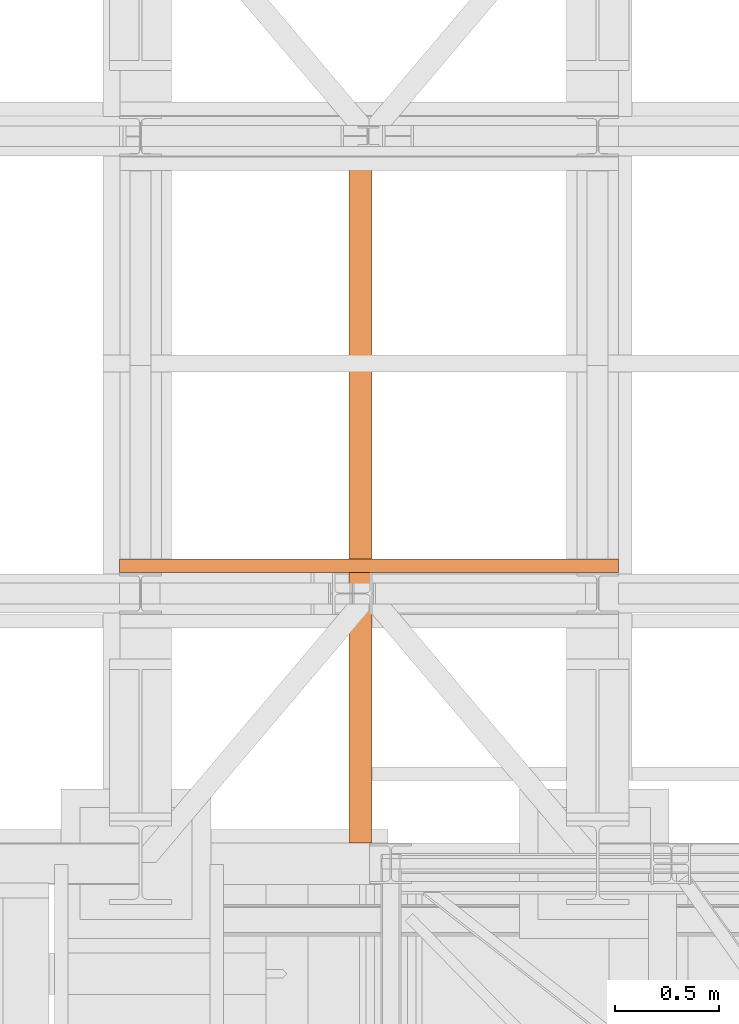
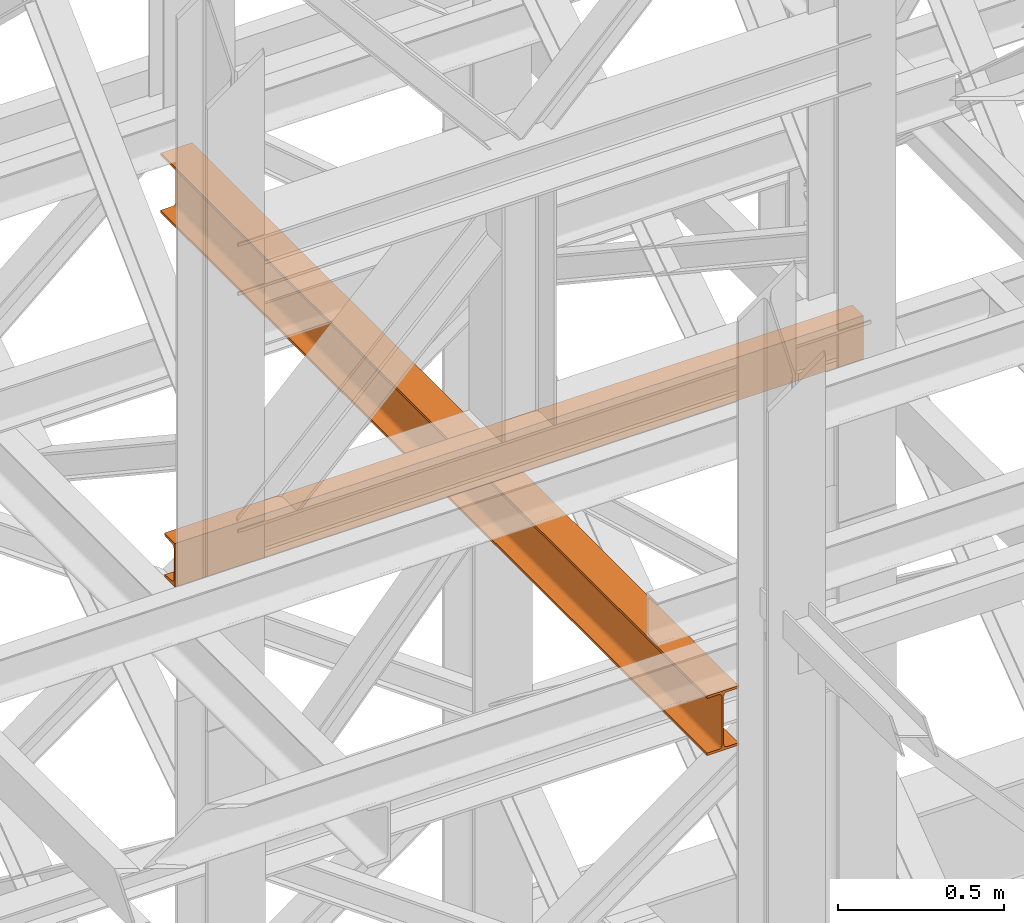
# One storey, part 111 of 208: 2 proxies.
"""IFC2X3 building model written with IfcOpenShell, lengths in millimetres."""

from ifc_helpers import new_model, entity, si_unit, converted_unit, frame, origin, origin_with_axes, place, context, subcontext, project, spatial, faceted_brep, element, save


model = new_model("IFC2X3")

# Units and contexts
model_context = context("Model", 3, precision=1e-05, world=origin())
plan_context = context("Plan", 3, precision=1e-05, world=origin())
body_context = subcontext(model_context, "Body", "Model", "MODEL_VIEW")
ifc_project = project(units=[si_unit("LENGTHUNIT", "METRE", prefix="MILLI"), converted_unit("PLANEANGLEUNIT", "DEGREE", entity("IfcPlaneAngleMeasure", 0.0174532925199433), si_unit("PLANEANGLEUNIT", "RADIAN"), dimensions=[0, 0, 0, 0, 0, 0, 0]), si_unit("AREAUNIT", "SQUARE_METRE"), si_unit("VOLUMEUNIT", "CUBIC_METRE")], contexts=[model_context, plan_context])

# Building, storey
building_placement = place(None, origin())
building = spatial("IfcBuilding", under=ifc_project, at=building_placement, CompositionType="COMPLEX")
storey_placement = place(building_placement, origin_with_axes())
storey = spatial("IfcBuildingStorey", under=building, at=storey_placement, Name="Geschoss", CompositionType="ELEMENT")

# Proxies
proxy_1_placement = place(storey_placement, frame((-106.7741512795017, -15862.57605638884, 9699.99), z_axis=(0.0, 0.0, 1.0), x_axis=(1.0, 0.0, 0.0)))
element("IfcBuildingElementProxy", 1, at=proxy_1_placement, inside=storey, context=body_context, shape_type="Brep", body=[
    faceted_brep([(0.009999999999990905, 65.01181901812197, 0.01000000000021828), (2399.826087056121, 65.01000000000022, 0.01000000000021828), (2399.826087056121, 65.01000000000022, 3.132428070246533), (0.009999999999990905, 65.01181901812197, 3.132428070246533), (0.009999999999990905, 65.01181901812197, 3.132428070246533), (2399.826087056121, 65.01000000000022, 3.132428070246533), (2399.826087056121, 64.76726342282564, 4.748288908171162), (0.009999999999990905, 64.7690824409492, 4.748288908171162), (0.009999999999990905, 64.7690824409492, 4.748288908171162), (2399.826087056121, 64.76726342282564, 4.748288908171162), (2399.826087056121, 64.06053228585552, 6.221534443444398), (0.009999999999990905, 64.06235130397909, 6.221534443444398), (0.009999999999990905, 64.06235130397909, 6.221534443444398), (2399.826087056121, 64.06053228585552, 6.221534443444398), (2399.826087056121, 62.95215163846842, 7.422126703873801), (0.009999999999990905, 62.95397065659199, 7.422126703873801), (0.009999999999990905, 62.95397065659199, 7.422126703873801), (2399.826087056121, 62.95215163846842, 7.422126703873801), (2399.826087056121, 61.53995641148504, 8.244091391710754), (0.009999999999990905, 61.54177542960679, 8.244091391710754), (0.009999999999990905, 61.54177542960679, 8.244091391710754), (2399.826087056121, 61.53995641148504, 8.244091391710754), (2399.826087056121, 59.9485987225562, 8.614912102195376), (0.009999999999990905, 59.95041774067795, 8.614912102195376), (0.009999999999990905, 59.95041774067795, 8.614912102195376), (2399.826087056121, 59.9485987225562, 8.614912102195376), (2399.826087056121, 17.17267516602988, 12.0369859867169), (0.009999999999990905, 17.17449418415163, 12.0369859867169), (0.009999999999990905, 17.17449418415163, 12.0369859867169), (2399.826087056121, 17.17267516602988, 12.0369859867169), (2399.826087056121, 14.13462866898408, 12.74491643400506), (0.009999999999990905, 14.13644768710583, 12.74491643400506), (0.009999999999990905, 14.13644768710583, 12.74491643400506), (2399.826087056121, 14.13462866898408, 12.74491643400506), (2399.826087056121, 11.43861959928654, 14.31412174714933), (0.009999999999990905, 11.44043861740829, 14.31412174714933), (0.009999999999990905, 11.44043861740829, 14.31412174714933), (2399.826087056121, 11.43861959928654, 14.31412174714933), (2399.826087056121, 9.322620181546881, 16.60616151705835), (0.009999999999990905, 9.324439199668632, 16.60616151705835), (0.009999999999990905, 9.324439199668632, 16.60616151705835), (2399.826087056121, 9.322620181546881, 16.60616151705835), (2399.826087056121, 7.973406192784751, 19.41872117530875), (0.009999999999990905, 7.97522521090832, 19.41872117530875), (0.009999999999990905, 7.97522521090832, 19.41872117530875), (2399.826087056121, 7.973406192784751, 19.41872117530875), (2399.826087056121, 7.510000000000218, 22.50354641134618), (0.009999999999990905, 7.511819018121969, 22.50354641134618), (0.009999999999990905, 7.511819018121969, 22.50354641134618), (2399.826087056121, 7.510000000000218, 22.50354641134618), (2399.826087056121, 7.510000000000218, 137.5164535886524), (0.009999999999990905, 7.511819018121969, 137.5164535886524), (0.009999999999990905, 7.511819018121969, 137.5164535886524), (2399.826087056121, 7.510000000000218, 137.5164535886524), (2399.826087056121, 7.973406192784751, 140.6012788246917), (0.009999999999990905, 7.97522521090832, 140.6012788246917), (0.009999999999990905, 7.97522521090832, 140.6012788246917), (2399.826087056121, 7.973406192784751, 140.6012788246917), (2399.826087056121, 9.322620181546881, 143.4138384829403), (0.009999999999990905, 9.324439199668632, 143.4138384829403), (0.009999999999990905, 9.324439199668632, 143.4138384829403), (2399.826087056121, 9.322620181546881, 143.4138384829403), (2399.826087056121, 11.43861959928654, 145.7058782528493), (0.009999999999990905, 11.44043861740829, 145.7058782528493), (0.009999999999990905, 11.44043861740829, 145.7058782528493), (2399.826087056121, 11.43861959928654, 145.7058782528493), (2399.826087056121, 14.13462866898408, 147.2750835659936), (0.009999999999990905, 14.13644768710583, 147.2750835659936), (0.009999999999990905, 14.13644768710583, 147.2750835659936), (2399.826087056121, 14.13462866898408, 147.2750835659936), (2399.826087056121, 17.17267516602988, 147.9830140132817), (0.009999999999990905, 17.17449418415163, 147.9830140132817), (0.009999999999990905, 17.17449418415163, 147.9830140132817), (2399.826087056121, 17.17267516602988, 147.9830140132817), (2399.826087056121, 59.9485987225562, 151.4050878978032), (0.009999999999990905, 59.95041774067795, 151.4050878978032), (0.009999999999990905, 59.95041774067795, 151.4050878978032), (2399.826087056121, 59.9485987225562, 151.4050878978032), (2399.826087056121, 61.53995641148504, 151.7759086082879), (0.009999999999990905, 61.54177542960679, 151.7759086082879), (0.009999999999990905, 61.54177542960679, 151.7759086082879), (2399.826087056121, 61.53995641148504, 151.7759086082879), (2399.826087056121, 62.95215163846842, 152.5978732961248), (0.009999999999990905, 62.95397065659199, 152.5978732961248), (0.009999999999990905, 62.95397065659199, 152.5978732961248), (2399.826087056121, 62.95215163846842, 152.5978732961248), (2399.826087056121, 64.06053228585552, 153.7984655565542), (0.009999999999990905, 64.06235130397909, 153.7984655565542), (0.009999999999990905, 64.06235130397909, 153.7984655565542), (2399.826087056121, 64.06053228585552, 153.7984655565542), (2399.826087056121, 64.76726342282564, 155.2717110918275), (0.009999999999990905, 64.7690824409492, 155.2717110918275), (0.009999999999990905, 64.7690824409492, 155.2717110918275), (2399.826087056121, 64.76726342282564, 155.2717110918275), (2399.826087056121, 65.01000000000022, 156.8875719297521), (0.009999999999990905, 65.01181901812197, 156.8875719297521), (0.009999999999990905, 65.01181901812197, 156.8875719297521), (2399.826087056121, 65.01000000000022, 156.8875719297521), (2399.826087056121, 65.01000000000022, 160.0100000000002), (0.009999999999990905, 65.01181901812197, 160.0100000000002), (0.009999999999990905, 65.01181901812197, 160.0100000000002), (2399.826087056121, 65.01000000000022, 160.0100000000002), (2399.826087056121, 0.01000000000021828, 160.0100000000002), (0.009999999999990905, 0.01181901812196884, 160.0100000000002), (0.009999999999990905, 0.01181901812196884, 160.0100000000002), (2399.826087056121, 0.01000000000021828, 160.0100000000002), (2399.826087056121, 0.01000000000021828, 0.01000000000021828), (0.009999999999990905, 0.01181901812196884, 0.01000000000021828), (0.009999999999990905, 0.01181901812196884, 0.01000000000021828), (2399.826087056121, 0.01000000000021828, 0.01000000000021828), (2399.826087056121, 65.01000000000022, 0.01000000000021828), (0.009999999999990905, 65.01181901812197, 0.01000000000021828), (0.009999999999990905, 65.01181901812197, 0.01000000000021828), (0.009999999999990905, 65.01181901812197, 3.132428070246533), (0.009999999999990905, 64.7690824409492, 4.748288908171162), (0.009999999999990905, 64.06235130397909, 6.221534443444398), (0.009999999999990905, 62.95397065659199, 7.422126703873801), (0.009999999999990905, 61.54177542960679, 8.244091391710754), (0.009999999999990905, 59.95041774067795, 8.614912102195376), (0.009999999999990905, 17.17449418415163, 12.0369859867169), (0.009999999999990905, 14.13644768710583, 12.74491643400506), (0.009999999999990905, 11.44043861740829, 14.31412174714933), (0.009999999999990905, 9.324439199668632, 16.60616151705835), (0.009999999999990905, 7.97522521090832, 19.41872117530875), (0.009999999999990905, 7.511819018121969, 22.50354641134618), (0.009999999999990905, 7.511819018121969, 137.5164535886524), (0.009999999999990905, 7.97522521090832, 140.6012788246917), (0.009999999999990905, 9.324439199668632, 143.4138384829403), (0.009999999999990905, 11.44043861740829, 145.7058782528493), (0.009999999999990905, 14.13644768710583, 147.2750835659936), (0.009999999999990905, 17.17449418415163, 147.9830140132817), (0.009999999999990905, 59.95041774067795, 151.4050878978032), (0.009999999999990905, 61.54177542960679, 151.7759086082879), (0.009999999999990905, 62.95397065659199, 152.5978732961248), (0.009999999999990905, 64.06235130397909, 153.7984655565542), (0.009999999999990905, 64.7690824409492, 155.2717110918275), (0.009999999999990905, 65.01181901812197, 156.8875719297521), (0.009999999999990905, 65.01181901812197, 160.0100000000002), (0.009999999999990905, 0.01181901812196884, 160.0100000000002), (0.009999999999990905, 0.01181901812196884, 0.01000000000021828), (2399.826087056121, 65.01000000000022, 0.01000000000021828), (2399.826087056121, 0.01000000000021828, 0.01000000000021828), (2399.826087056121, 0.01000000000021828, 160.0100000000002), (2399.826087056121, 65.01000000000022, 160.0100000000002), (2399.826087056121, 65.01000000000022, 156.8875719297521), (2399.826087056121, 64.76726342282564, 155.2717110918275), (2399.826087056121, 64.06053228585552, 153.7984655565542), (2399.826087056121, 62.95215163846842, 152.5978732961248), (2399.826087056121, 61.53995641148504, 151.7759086082879), (2399.826087056121, 59.9485987225562, 151.4050878978032), (2399.826087056121, 17.17267516602988, 147.9830140132817), (2399.826087056121, 14.13462866898408, 147.2750835659936), (2399.826087056121, 11.43861959928654, 145.7058782528493), (2399.826087056121, 9.322620181546881, 143.4138384829403), (2399.826087056121, 7.973406192784751, 140.6012788246917), (2399.826087056121, 7.510000000000218, 137.5164535886524), (2399.826087056121, 7.510000000000218, 22.50354641134618), (2399.826087056121, 7.973406192784751, 19.41872117530875), (2399.826087056121, 9.322620181546881, 16.60616151705835), (2399.826087056121, 11.43861959928654, 14.31412174714933), (2399.826087056121, 14.13462866898408, 12.74491643400506), (2399.826087056121, 17.17267516602988, 12.0369859867169), (2399.826087056121, 59.9485987225562, 8.614912102195376), (2399.826087056121, 61.53995641148504, 8.244091391710754), (2399.826087056121, 62.95215163846842, 7.422126703873801), (2399.826087056121, 64.06053228585552, 6.221534443444398), (2399.826087056121, 64.76726342282564, 4.748288908171162), (2399.826087056121, 65.01000000000022, 3.132428070246533)], [[[0, 1, 2, 3]], [[4, 5, 6, 7]], [[8, 9, 10, 11]], [[12, 13, 14, 15]], [[16, 17, 18, 19]], [[20, 21, 22, 23]], [[24, 25, 26, 27]], [[28, 29, 30, 31]], [[32, 33, 34, 35]], [[36, 37, 38, 39]], [[40, 41, 42, 43]], [[44, 45, 46, 47]], [[48, 49, 50, 51]], [[52, 53, 54, 55]], [[56, 57, 58, 59]], [[60, 61, 62, 63]], [[64, 65, 66, 67]], [[68, 69, 70, 71]], [[72, 73, 74, 75]], [[76, 77, 78, 79]], [[80, 81, 82, 83]], [[84, 85, 86, 87]], [[88, 89, 90, 91]], [[92, 93, 94, 95]], [[96, 97, 98, 99]], [[100, 101, 102, 103]], [[104, 105, 106, 107]], [[108, 109, 110, 111]], [[112, 113, 114, 115, 116, 117, 118, 119, 120, 121, 122, 123, 124, 125, 126, 127, 128, 129, 130, 131, 132, 133, 134, 135, 136, 137, 138, 139]], [[140, 141, 142, 143, 144, 145, 146, 147, 148, 149, 150, 151, 152, 153, 154, 155, 156, 157, 158, 159, 160, 161, 162, 163, 164, 165, 166, 167]]], orient=[[False], [False], [False], [False], [False], [False], [False], [False], [False], [False], [False], [False], [False], [False], [False], [False], [False], [False], [False], [False], [False], [False], [False], [False], [False], [False], [False], [False], [False], [False]]),
])
proxy_2_placement = place(storey_placement, frame((997.4990363434483, -17162.58508944891, 9479.99), z_axis=(0.0, 0.0, 1.0), x_axis=(1.0, 0.0, 0.0)))
element("IfcBuildingElementProxy", 2, at=proxy_2_placement, inside=storey, Name="3D Element", context=body_context, shape_type="Brep", body=[
    faceted_brep([(0.009999999999990905, 3299.938194702263, 9.209999809265355), (0.009999999999990905, 3299.938194702263, 0.01000000000021828), (110.01, 3299.938194702263, 0.01000000000021828), (110.01, 3299.938194702263, 9.209999809265355), (70.57913068098946, 3299.938194702263, 9.209999809265355), (66.25180869396877, 3299.938194702263, 9.797362501594762), (62.90658890732789, 3299.938194702263, 11.50181071442057), (60.25181095283892, 3299.938194702263, 14.15658866890954), (58.54736274001311, 3299.938194702263, 17.50180845555042), (57.96000004768371, 3299.938194702263, 21.20999980926536), (57.96000004768371, 3299.938194702263, 198.8100001907351), (58.3689252976817, 3299.938194702263, 201.915818315525), (59.56772743354645, 3299.938194702263, 204.8099826905327), (61.47471867344552, 3299.938194702263, 207.2952815649733), (63.9600175478879, 3299.938194702263, 209.2022728048742), (66.85418192289376, 3299.938194702263, 210.4010749407371), (69.9600000476837, 3299.938194702263, 210.8100001907351), (110.01, 3299.938194702263, 210.8100001907351), (110.01, 3299.938194702263, 220.0100000000002), (0.009999999999990905, 3299.938194702263, 220.0100000000002), (0.009999999999990905, 3299.938194702263, 210.8100001907351), (40.05999995231628, 3299.938194702263, 210.8100001907351), (43.16581807710622, 3299.938194702263, 210.4010749407371), (46.0599824521139, 3299.938194702263, 209.2022728048742), (48.54528132655446, 3299.938194702263, 207.2952815649733), (50.52982171082635, 3299.938194702263, 204.6227624944386), (51.6510747023201, 3299.938194702263, 201.915818315525), (52.05999995231628, 3299.938194702263, 198.8100001907351), (52.05999995231628, 3299.938194702263, 21.20999980926536), (51.6510747023201, 3299.938194702263, 18.10418168447541), (50.45227256645535, 3299.938194702263, 15.21001730946955), (48.54528132655446, 3299.938194702263, 12.72471843502717), (46.0599824521139, 3299.938194702263, 10.81772719512628), (43.16581807710622, 3299.938194702263, 9.618925059263347), (40.05999995231628, 3299.938194702263, 9.209999809265355), (0.009999999999990905, 3299.938194702263, 0.01000000000021828), (0.009999999999990905, 3299.938194702263, 9.209999809265355), (0.009999999999990905, 0.00999999999839929, 9.209999809265355), (0.009999999999990905, 0.00999999999839929, 0.01000000000021828), (110.01, 3299.938194702263, 0.01000000000021828), (0.009999999999990905, 3299.938194702263, 0.01000000000021828), (0.009999999999990905, 0.00999999999839929, 0.01000000000021828), (110.01, 0.00999999999839929, 0.01000000000021828), (110.01, 3299.938194702263, 9.209999809265355), (110.01, 3299.938194702263, 0.01000000000021828), (110.01, 0.00999999999839929, 0.01000000000021828), (110.01, 0.00999999999839929, 9.209999809265355), (70.57913068098946, 3299.938194702263, 9.209999809265355), (110.01, 3299.938194702263, 9.209999809265355), (110.01, 0.00999999999839929, 9.209999809265355), (70.57913068098946, 0.00999999999839929, 9.209999809265355), (66.25180869396877, 3299.938194702263, 9.797362501594762), (70.57913068098946, 3299.938194702263, 9.209999809265355), (70.57913068098946, 0.00999999999839929, 9.209999809265355), (66.25180869396877, 0.00999999999839929, 9.797362501594762), (62.90658890732789, 3299.938194702263, 11.50181071442057), (66.25180869396877, 3299.938194702263, 9.797362501594762), (66.25180869396877, 0.00999999999839929, 9.797362501594762), (62.90658890732789, 0.00999999999839929, 11.50181071442057), (60.25181095283892, 3299.938194702263, 14.15658866890954), (62.90658890732789, 3299.938194702263, 11.50181071442057), (62.90658890732789, 0.00999999999839929, 11.50181071442057), (60.25181095283892, 0.00999999999839929, 14.15658866890954), (58.54736274001311, 3299.938194702263, 17.50180845555042), (60.25181095283892, 3299.938194702263, 14.15658866890954), (60.25181095283892, 0.00999999999839929, 14.15658866890954), (58.54736274001311, 0.00999999999839929, 17.50180845555042), (57.96000004768371, 3299.938194702263, 21.20999980926536), (58.54736274001311, 3299.938194702263, 17.50180845555042), (58.54736274001311, 0.00999999999839929, 17.50180845555042), (57.96000004768371, 0.00999999999839929, 21.20999980926536), (57.96000004768371, 3299.938194702263, 198.8100001907351), (57.96000004768371, 3299.938194702263, 21.20999980926536), (57.96000004768371, 0.00999999999839929, 21.20999980926536), (57.96000004768371, 0.00999999999839929, 198.8100001907351), (58.3689252976817, 3299.938194702263, 201.915818315525), (57.96000004768371, 3299.938194702263, 198.8100001907351), (57.96000004768371, 0.00999999999839929, 198.8100001907351), (58.3689252976817, 0.00999999999839929, 201.915818315525), (59.56772743354645, 3299.938194702263, 204.8099826905327), (58.3689252976817, 3299.938194702263, 201.915818315525), (58.3689252976817, 0.00999999999839929, 201.915818315525), (59.56772743354645, 0.00999999999839929, 204.8099826905327), (61.47471867344552, 3299.938194702263, 207.2952815649733), (59.56772743354645, 3299.938194702263, 204.8099826905327), (59.56772743354645, 0.00999999999839929, 204.8099826905327), (61.47471867344552, 0.00999999999839929, 207.2952815649733), (63.9600175478879, 3299.938194702263, 209.2022728048742), (61.47471867344552, 3299.938194702263, 207.2952815649733), (61.47471867344552, 0.00999999999839929, 207.2952815649733), (63.9600175478879, 0.00999999999839929, 209.2022728048742), (66.85418192289376, 3299.938194702263, 210.4010749407371), (63.9600175478879, 3299.938194702263, 209.2022728048742), (63.9600175478879, 0.00999999999839929, 209.2022728048742), (66.85418192289376, 0.00999999999839929, 210.4010749407371), (69.9600000476837, 3299.938194702263, 210.8100001907351), (66.85418192289376, 3299.938194702263, 210.4010749407371), (66.85418192289376, 0.00999999999839929, 210.4010749407371), (69.9600000476837, 0.00999999999839929, 210.8100001907351), (110.01, 3299.938194702263, 210.8100001907351), (69.9600000476837, 3299.938194702263, 210.8100001907351), (69.9600000476837, 0.00999999999839929, 210.8100001907351), (110.01, 0.00999999999839929, 210.8100001907351), (110.01, 3299.938194702263, 220.0100000000002), (110.01, 3299.938194702263, 210.8100001907351), (110.01, 0.00999999999839929, 210.8100001907351), (110.01, 0.00999999999839929, 220.0100000000002), (0.009999999999990905, 3299.938194702263, 220.0100000000002), (110.01, 3299.938194702263, 220.0100000000002), (110.01, 0.00999999999839929, 220.0100000000002), (0.009999999999990905, 0.00999999999839929, 220.0100000000002), (0.009999999999990905, 3299.938194702263, 210.8100001907351), (0.009999999999990905, 3299.938194702263, 220.0100000000002), (0.009999999999990905, 0.00999999999839929, 220.0100000000002), (0.009999999999990905, 0.00999999999839929, 210.8100001907351), (40.05999995231628, 3299.938194702263, 210.8100001907351), (0.009999999999990905, 3299.938194702263, 210.8100001907351), (0.009999999999990905, 0.00999999999839929, 210.8100001907351), (40.05999995231628, 0.00999999999839929, 210.8100001907351), (43.16581807710622, 3299.938194702263, 210.4010749407371), (40.05999995231628, 3299.938194702263, 210.8100001907351), (40.05999995231628, 0.00999999999839929, 210.8100001907351), (43.16581807710622, 0.00999999999839929, 210.4010749407371), (46.0599824521139, 3299.938194702263, 209.2022728048742), (43.16581807710622, 3299.938194702263, 210.4010749407371), (43.16581807710622, 0.00999999999839929, 210.4010749407371), (46.0599824521139, 0.00999999999839929, 209.2022728048742), (48.54528132655446, 3299.938194702263, 207.2952815649733), (46.0599824521139, 3299.938194702263, 209.2022728048742), (46.0599824521139, 0.00999999999839929, 209.2022728048742), (48.54528132655446, 0.00999999999839929, 207.2952815649733), (50.52982171082635, 3299.938194702263, 204.6227624944386), (48.54528132655446, 3299.938194702263, 207.2952815649733), (48.54528132655446, 0.00999999999839929, 207.2952815649733), (50.52982171082635, 0.00999999999839929, 204.6227624944386), (51.6510747023201, 3299.938194702263, 201.915818315525), (50.52982171082635, 3299.938194702263, 204.6227624944386), (50.52982171082635, 0.00999999999839929, 204.6227624944386), (51.6510747023201, 0.00999999999839929, 201.915818315525), (52.05999995231628, 3299.938194702263, 198.8100001907351), (51.6510747023201, 3299.938194702263, 201.915818315525), (51.6510747023201, 0.00999999999839929, 201.915818315525), (52.05999995231628, 0.00999999999839929, 198.8100001907351), (52.05999995231628, 3299.938194702263, 21.20999980926536), (52.05999995231628, 3299.938194702263, 198.8100001907351), (52.05999995231628, 0.00999999999839929, 198.8100001907351), (52.05999995231628, 0.00999999999839929, 21.20999980926536), (51.6510747023201, 3299.938194702263, 18.10418168447541), (52.05999995231628, 3299.938194702263, 21.20999980926536), (52.05999995231628, 0.00999999999839929, 21.20999980926536), (51.6510747023201, 0.00999999999839929, 18.10418168447541), (50.45227256645535, 3299.938194702263, 15.21001730946955), (51.6510747023201, 3299.938194702263, 18.10418168447541), (51.6510747023201, 0.00999999999839929, 18.10418168447541), (50.45227256645535, 0.00999999999839929, 15.21001730946955), (48.54528132655446, 3299.938194702263, 12.72471843502717), (50.45227256645535, 3299.938194702263, 15.21001730946955), (50.45227256645535, 0.00999999999839929, 15.21001730946955), (48.54528132655446, 0.00999999999839929, 12.72471843502717), (46.0599824521139, 3299.938194702263, 10.81772719512628), (48.54528132655446, 3299.938194702263, 12.72471843502717), (48.54528132655446, 0.00999999999839929, 12.72471843502717), (46.0599824521139, 0.00999999999839929, 10.81772719512628), (43.16581807710622, 3299.938194702263, 9.618925059263347), (46.0599824521139, 3299.938194702263, 10.81772719512628), (46.0599824521139, 0.00999999999839929, 10.81772719512628), (43.16581807710622, 0.00999999999839929, 9.618925059263347), (40.05999995231628, 3299.938194702263, 9.209999809265355), (43.16581807710622, 3299.938194702263, 9.618925059263347), (43.16581807710622, 0.00999999999839929, 9.618925059263347), (40.05999995231628, 0.00999999999839929, 9.209999809265355), (0.009999999999990905, 3299.938194702263, 9.209999809265355), (40.05999995231628, 3299.938194702263, 9.209999809265355), (40.05999995231628, 0.00999999999839929, 9.209999809265355), (0.009999999999990905, 0.00999999999839929, 9.209999809265355), (0.009999999999990905, 0.00999999999839929, 9.209999809265355), (40.05999995231628, 0.00999999999839929, 9.209999809265355), (43.16581807710622, 0.00999999999839929, 9.618925059263347), (46.0599824521139, 0.00999999999839929, 10.81772719512628), (48.54528132655446, 0.00999999999839929, 12.72471843502717), (50.45227256645535, 0.00999999999839929, 15.21001730946955), (51.6510747023201, 0.00999999999839929, 18.10418168447541), (52.05999995231628, 0.00999999999839929, 21.20999980926536), (52.05999995231628, 0.00999999999839929, 198.8100001907351), (51.6510747023201, 0.00999999999839929, 201.915818315525), (50.52982171082635, 0.00999999999839929, 204.6227624944386), (48.54528132655446, 0.00999999999839929, 207.2952815649733), (46.0599824521139, 0.00999999999839929, 209.2022728048742), (43.16581807710622, 0.00999999999839929, 210.4010749407371), (40.05999995231628, 0.00999999999839929, 210.8100001907351), (0.009999999999990905, 0.00999999999839929, 210.8100001907351), (0.009999999999990905, 0.00999999999839929, 220.0100000000002), (110.01, 0.00999999999839929, 220.0100000000002), (110.01, 0.00999999999839929, 210.8100001907351), (69.9600000476837, 0.00999999999839929, 210.8100001907351), (66.85418192289376, 0.00999999999839929, 210.4010749407371), (63.9600175478879, 0.00999999999839929, 209.2022728048742), (61.47471867344552, 0.00999999999839929, 207.2952815649733), (59.56772743354645, 0.00999999999839929, 204.8099826905327), (58.3689252976817, 0.00999999999839929, 201.915818315525), (57.96000004768371, 0.00999999999839929, 198.8100001907351), (57.96000004768371, 0.00999999999839929, 21.20999980926536), (58.54736274001311, 0.00999999999839929, 17.50180845555042), (60.25181095283892, 0.00999999999839929, 14.15658866890954), (62.90658890732789, 0.00999999999839929, 11.50181071442057), (66.25180869396877, 0.00999999999839929, 9.797362501594762), (70.57913068098946, 0.00999999999839929, 9.209999809265355), (110.01, 0.00999999999839929, 9.209999809265355), (110.01, 0.00999999999839929, 0.01000000000021828), (0.009999999999990905, 0.00999999999839929, 0.01000000000021828)], [[[0, 1, 2, 3, 4, 5, 6, 7, 8, 9, 10, 11, 12, 13, 14, 15, 16, 17, 18, 19, 20, 21, 22, 23, 24, 25, 26, 27, 28, 29, 30, 31, 32, 33, 34]], [[35, 36, 37, 38]], [[39, 40, 41, 42]], [[43, 44, 45, 46]], [[47, 48, 49, 50]], [[51, 52, 53, 54]], [[55, 56, 57, 58]], [[59, 60, 61, 62]], [[63, 64, 65, 66]], [[67, 68, 69, 70]], [[71, 72, 73, 74]], [[75, 76, 77, 78]], [[79, 80, 81, 82]], [[83, 84, 85, 86]], [[87, 88, 89, 90]], [[91, 92, 93, 94]], [[95, 96, 97, 98]], [[99, 100, 101, 102]], [[103, 104, 105, 106]], [[107, 108, 109, 110]], [[111, 112, 113, 114]], [[115, 116, 117, 118]], [[119, 120, 121, 122]], [[123, 124, 125, 126]], [[127, 128, 129, 130]], [[131, 132, 133, 134]], [[135, 136, 137, 138]], [[139, 140, 141, 142]], [[143, 144, 145, 146]], [[147, 148, 149, 150]], [[151, 152, 153, 154]], [[155, 156, 157, 158]], [[159, 160, 161, 162]], [[163, 164, 165, 166]], [[167, 168, 169, 170]], [[171, 172, 173, 174]], [[175, 176, 177, 178, 179, 180, 181, 182, 183, 184, 185, 186, 187, 188, 189, 190, 191, 192, 193, 194, 195, 196, 197, 198, 199, 200, 201, 202, 203, 204, 205, 206, 207, 208, 209]]], orient=[[False], [False], [False], [False], [False], [False], [False], [False], [False], [False], [False], [False], [False], [False], [False], [False], [False], [False], [False], [False], [False], [False], [False], [False], [False], [False], [False], [False], [False], [False], [False], [False], [False], [False], [False], [False], [False]]),
])

save(model, "model.ifc")
